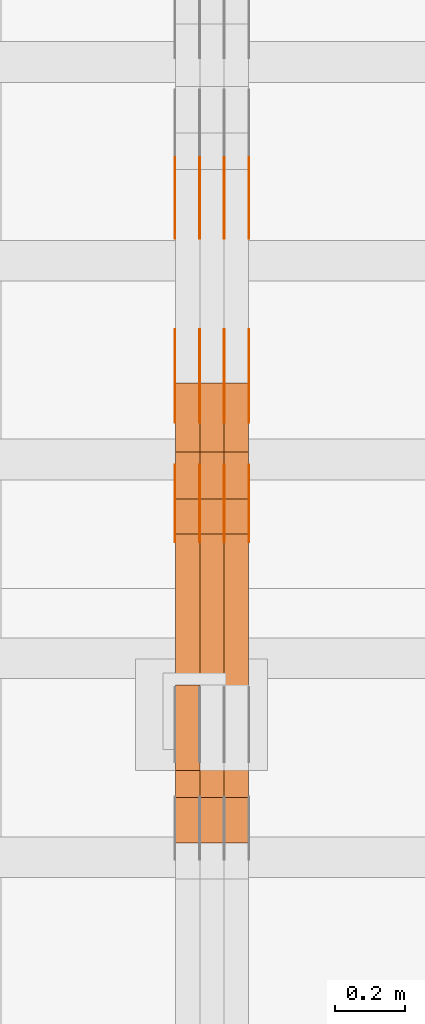
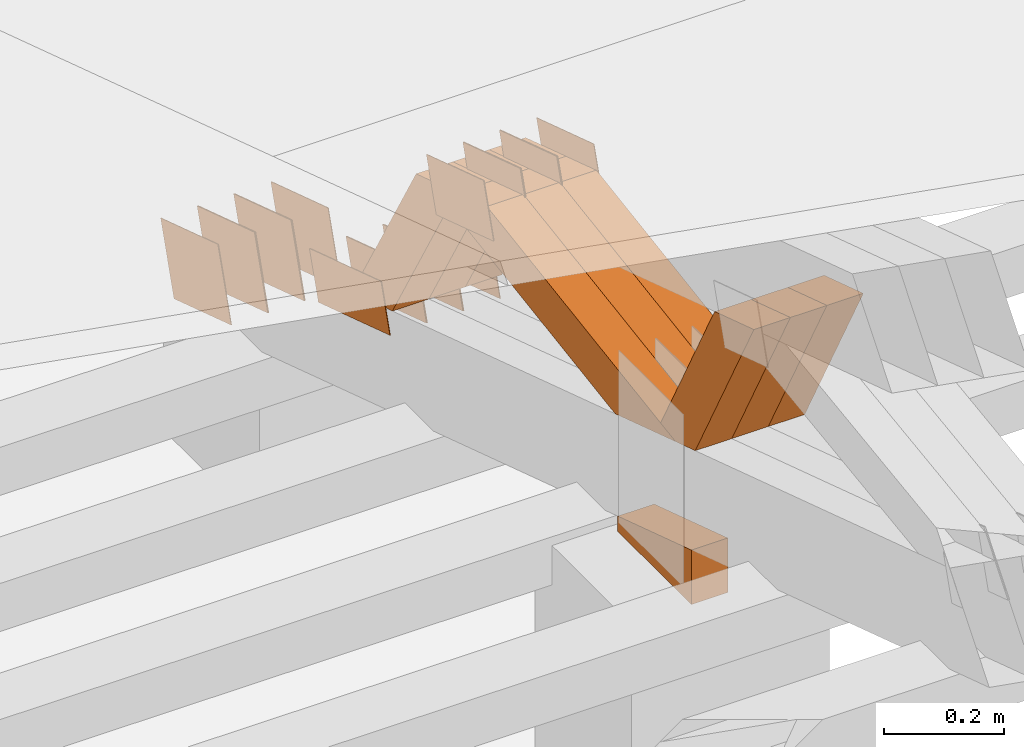
# One storey, part 304 of 385: 28 proxies.
"""IFC2X3 building model written with IfcOpenShell, lengths in millimetres."""

from ifc_helpers import new_model, entity, si_unit, converted_unit, derived_unit, direction, frame, origin, place, context, subcontext, project, spatial, polyline, outline, extrude, source, transform, mapped, material, type_object, type_shapes, element, save


model = new_model("IFC2X3")

# Units and contexts
model_context = context("Model", 3, precision=0.01, world=origin(), true_north=direction((6.12303176911189e-17, 1.0)))
body_context = subcontext(model_context, "Body", "Model", "MODEL_VIEW")
ifc_project = project(units=[si_unit("LENGTHUNIT", "METRE", prefix="MILLI"), si_unit("AREAUNIT", "SQUARE_METRE"), si_unit("VOLUMEUNIT", "CUBIC_METRE"), converted_unit("PLANEANGLEUNIT", "DEGREE", entity("IfcRatioMeasure", 0.0174532925199433), si_unit("PLANEANGLEUNIT", "RADIAN"), dimensions=[0, 0, 0, 0, 0, 0, 0]), si_unit("MASSUNIT", "GRAM", prefix="KILO"), derived_unit("MASSDENSITYUNIT", [(si_unit("MASSUNIT", "GRAM", prefix="KILO"), 1), (si_unit("LENGTHUNIT", "METRE"), -3)]), si_unit("TIMEUNIT", "SECOND"), si_unit("FREQUENCYUNIT", "HERTZ"), si_unit("THERMODYNAMICTEMPERATUREUNIT", "DEGREE_CELSIUS"), derived_unit("THERMALTRANSMITTANCEUNIT", [(si_unit("MASSUNIT", "GRAM", prefix="KILO"), 1), (si_unit("THERMODYNAMICTEMPERATUREUNIT", "KELVIN"), -1), (si_unit("TIMEUNIT", "SECOND"), -3)]), derived_unit("VOLUMETRICFLOWRATEUNIT", [(si_unit("LENGTHUNIT", "METRE"), 3), (si_unit("TIMEUNIT", "SECOND"), -1)]), si_unit("ELECTRICCURRENTUNIT", "AMPERE"), si_unit("ELECTRICVOLTAGEUNIT", "VOLT"), si_unit("POWERUNIT", "WATT"), si_unit("FORCEUNIT", "NEWTON", prefix="KILO"), si_unit("ILLUMINANCEUNIT", "LUX"), si_unit("LUMINOUSFLUXUNIT", "LUMEN"), si_unit("LUMINOUSINTENSITYUNIT", "CANDELA"), derived_unit("USERDEFINED", [(si_unit("MASSUNIT", "GRAM", prefix="KILO"), -1), (si_unit("LENGTHUNIT", "METRE"), -2), (si_unit("TIMEUNIT", "SECOND"), 3), (si_unit("LUMINOUSFLUXUNIT", "LUMEN"), 1)]), derived_unit("LINEARVELOCITYUNIT", [(si_unit("LENGTHUNIT", "METRE"), 1), (si_unit("TIMEUNIT", "SECOND"), -1)]), si_unit("PRESSUREUNIT", "PASCAL"), derived_unit("USERDEFINED", [(si_unit("LENGTHUNIT", "METRE"), -2), (si_unit("MASSUNIT", "GRAM", prefix="KILO"), 1), (si_unit("TIMEUNIT", "SECOND"), -2)])], contexts=[model_context])

# Site, building, storey
site_placement = place(None, origin())
site = spatial("IfcSite", under=ifc_project, at=site_placement, CompositionType="ELEMENT")
building_placement = place(site_placement, origin())
building = spatial("IfcBuilding", under=site, at=building_placement, CompositionType="ELEMENT")
storey_placement = place(building_placement, origin())
storey = spatial("IfcBuildingStorey", under=building, at=storey_placement, Name="Default", CompositionType="ELEMENT", Elevation=0.0)

# Proxies
ifc_material_1 = material(Name="IfcSurfaceStyle #549014")
building_element_proxy_type_1 = type_object("IfcBuildingElementProxyType", PredefinedType="NOTDEFINED", material=ifc_material_1)
shared_shape_1 = source(origin(), body_context, "Body", "SweptSolid", [
    extrude(outline(polyline([(-125.00031378339, -47.9999612158856), (125.000225258022, -47.9999612158856), (124.999811678525, 47.9999612158856), (-124.999723153156, 47.9999612158856), (-125.00031378339, -47.9999612158856)])), frame((125.000225258022, 48.0000091013474, 0.0), z_axis=(0.0, 0.0, 1.0), x_axis=(-1.0, 0.0, 0.0)), (0.0, 0.0, 1.0), 1.3),
])
type_shapes(building_element_proxy_type_1, [shared_shape_1])
proxy_1_placement = place(building_placement, frame((45386.3, 18456.8597683375, 2657.46691321253), z_axis=(-1.0, 0.0, 0.0), x_axis=(0.0, -0.951056516295124, 0.309016994375039)))
element("IfcBuildingElementProxy", 1, at=proxy_1_placement, inside=storey, type_object=building_element_proxy_type_1, material=ifc_material_1, context=body_context, shape_type="MappedRepresentation", body=[
    mapped(shared_shape_1, transform((0.0, 0.0, 0.0), scale=1.0)),
])
ifc_material_2 = material(Name="IfcSurfaceStyle #548957")
building_element_proxy_type_2 = type_object("IfcBuildingElementProxyType", PredefinedType="NOTDEFINED", material=ifc_material_2)
shared_shape_2 = source(origin(), body_context, "Body", "SweptSolid", [
    extrude(outline(polyline([(-125.00031378339, -47.9999612158856), (125.000225258022, -47.9999612158856), (124.999811678525, 47.9999612158856), (-124.999723153156, 47.9999612158856), (-125.00031378339, -47.9999612158856)])), frame((125.000225258022, 48.0000091013474, 0.0), z_axis=(0.0, 0.0, 1.0), x_axis=(-1.0, 0.0, 0.0)), (0.0, 0.0, 1.0), 1.3),
])
type_shapes(building_element_proxy_type_2, [shared_shape_2])
proxy_2_placement = place(building_placement, frame((45315.0, 18456.8597683375, 2657.46691321253), z_axis=(-1.0, 0.0, 0.0), x_axis=(0.0, -0.951056516295124, 0.309016994375039)))
element("IfcBuildingElementProxy", 2, at=proxy_2_placement, inside=storey, type_object=building_element_proxy_type_2, material=ifc_material_2, context=body_context, shape_type="MappedRepresentation", body=[
    mapped(shared_shape_2, transform((0.0, 0.0, 0.0), scale=1.0)),
])
ifc_material_3 = material(Name="IfcSurfaceStyle #548900")
building_element_proxy_type_3 = type_object("IfcBuildingElementProxyType", PredefinedType="NOTDEFINED", material=ifc_material_3)
shared_shape_3 = source(origin(), body_context, "Body", "SweptSolid", [
    extrude(outline(polyline([(-125.00031378339, -47.9999612158856), (125.000225258022, -47.9999612158856), (124.999811678525, 47.9999612158856), (-124.999723153156, 47.9999612158856), (-125.00031378339, -47.9999612158856)])), frame((125.000225258022, 48.0000091013474, 0.0), z_axis=(0.0, 0.0, 1.0), x_axis=(-1.0, 0.0, 0.0)), (0.0, 0.0, 1.0), 1.3),
])
type_shapes(building_element_proxy_type_3, [shared_shape_3])
proxy_3_placement = place(building_placement, frame((45316.3, 18456.8597683375, 2657.46691321253), z_axis=(-1.0, 0.0, 0.0), x_axis=(0.0, -0.951056516295124, 0.309016994375039)))
element("IfcBuildingElementProxy", 3, at=proxy_3_placement, inside=storey, type_object=building_element_proxy_type_3, material=ifc_material_3, context=body_context, shape_type="MappedRepresentation", body=[
    mapped(shared_shape_3, transform((0.0, 0.0, 0.0), scale=1.0)),
])
ifc_material_4 = material(Name="IfcSurfaceStyle #548843")
building_element_proxy_type_4 = type_object("IfcBuildingElementProxyType", PredefinedType="NOTDEFINED", material=ifc_material_4)
shared_shape_4 = source(origin(), body_context, "Body", "SweptSolid", [
    extrude(outline(polyline([(-125.00031378339, -47.9999612158856), (125.000225258022, -47.9999612158856), (124.999811678525, 47.9999612158856), (-124.999723153156, 47.9999612158856), (-125.00031378339, -47.9999612158856)])), frame((125.000225258022, 48.0000091013474, 0.0), z_axis=(0.0, 0.0, 1.0), x_axis=(-1.0, 0.0, 0.0)), (0.0, 0.0, 1.0), 1.29999999999998),
])
type_shapes(building_element_proxy_type_4, [shared_shape_4])
proxy_4_placement = place(building_placement, frame((45245.0, 18456.8597683375, 2657.46691321253), z_axis=(-1.0, 0.0, 0.0), x_axis=(0.0, -0.951056516295124, 0.309016994375039)))
element("IfcBuildingElementProxy", 4, at=proxy_4_placement, inside=storey, type_object=building_element_proxy_type_4, material=ifc_material_4, context=body_context, shape_type="MappedRepresentation", body=[
    mapped(shared_shape_4, transform((0.0, 0.0, 0.0), scale=1.0)),
])
ifc_material_5 = material(Name="IfcSurfaceStyle #548786")
building_element_proxy_type_5 = type_object("IfcBuildingElementProxyType", PredefinedType="NOTDEFINED", material=ifc_material_5)
shared_shape_5 = source(origin(), body_context, "Body", "SweptSolid", [
    extrude(outline(polyline([(-125.00031378339, -47.9999612158856), (125.000225258022, -47.9999612158856), (124.999811678525, 47.9999612158856), (-124.999723153156, 47.9999612158856), (-125.00031378339, -47.9999612158856)])), frame((125.000225258022, 48.0000091013474, 0.0), z_axis=(0.0, 0.0, 1.0), x_axis=(-1.0, 0.0, 0.0)), (0.0, 0.0, 1.0), 1.29999999999998),
])
type_shapes(building_element_proxy_type_5, [shared_shape_5])
proxy_5_placement = place(building_placement, frame((45246.3, 18456.8597683375, 2657.46691321253), z_axis=(-1.0, 0.0, 0.0), x_axis=(0.0, -0.951056516295124, 0.309016994375039)))
element("IfcBuildingElementProxy", 5, at=proxy_5_placement, inside=storey, type_object=building_element_proxy_type_5, material=ifc_material_5, context=body_context, shape_type="MappedRepresentation", body=[
    mapped(shared_shape_5, transform((0.0, 0.0, 0.0), scale=1.0)),
])
ifc_material_6 = material(Name="IfcSurfaceStyle #548729")
building_element_proxy_type_6 = type_object("IfcBuildingElementProxyType", PredefinedType="NOTDEFINED", material=ifc_material_6)
shared_shape_6 = source(origin(), body_context, "Body", "SweptSolid", [
    extrude(outline(polyline([(-125.00031378339, -47.9999612158856), (125.000225258022, -47.9999612158856), (124.999811678525, 47.9999612158856), (-124.999723153156, 47.9999612158856), (-125.00031378339, -47.9999612158856)])), frame((125.000225258022, 48.0000091013474, 0.0), z_axis=(0.0, 0.0, 1.0), x_axis=(-1.0, 0.0, 0.0)), (0.0, 0.0, 1.0), 1.29999999999998),
])
type_shapes(building_element_proxy_type_6, [shared_shape_6])
proxy_6_placement = place(building_placement, frame((45175.0, 18456.8597683375, 2657.46691321253), z_axis=(-1.0, 0.0, 0.0), x_axis=(0.0, -0.951056516295124, 0.309016994375039)))
element("IfcBuildingElementProxy", 6, at=proxy_6_placement, inside=storey, type_object=building_element_proxy_type_6, material=ifc_material_6, context=body_context, shape_type="MappedRepresentation", body=[
    mapped(shared_shape_6, transform((0.0, 0.0, 0.0), scale=1.0)),
])
ifc_material_7 = material(Name="IfcSurfaceStyle #547304")
building_element_proxy_type_7 = type_object("IfcBuildingElementProxyType", PredefinedType="NOTDEFINED", material=ifc_material_7)
shared_shape_7 = source(origin(), body_context, "Body", "SweptSolid", [
    extrude(outline(polyline([(-99.999796294464, -72.0000050220467), (99.9998768370438, -72.0000050220467), (100.000260677528, 72.0000050220467), (-100.000341220108, 72.0000050220467), (-99.999796294464, -72.0000050220467)])), frame((100.000260677528, 72.0000050220467, 0.0), z_axis=(0.0, 0.0, 1.0), x_axis=(-1.0, 0.0, 0.0)), (0.0, 0.0, 1.0), 1.3),
])
type_shapes(building_element_proxy_type_7, [shared_shape_7])
proxy_7_placement = place(building_placement, frame((45386.3, 18936.3876569477, 2373.90613192527), z_axis=(-1.0, 0.0, 0.0), x_axis=(0.0, -0.951056516295124, 0.309016994375039)))
element("IfcBuildingElementProxy", 7, at=proxy_7_placement, inside=storey, type_object=building_element_proxy_type_7, material=ifc_material_7, context=body_context, shape_type="MappedRepresentation", body=[
    mapped(shared_shape_7, transform((0.0, 0.0, 0.0), scale=1.0)),
])
ifc_material_8 = material(Name="IfcSurfaceStyle #547247")
building_element_proxy_type_8 = type_object("IfcBuildingElementProxyType", PredefinedType="NOTDEFINED", material=ifc_material_8)
shared_shape_8 = source(origin(), body_context, "Body", "SweptSolid", [
    extrude(outline(polyline([(-99.999796294464, -72.0000050220467), (99.9998768370438, -72.0000050220467), (100.000260677528, 72.0000050220467), (-100.000341220108, 72.0000050220467), (-99.999796294464, -72.0000050220467)])), frame((100.000260677528, 72.0000050220467, 0.0), z_axis=(0.0, 0.0, 1.0), x_axis=(-1.0, 0.0, 0.0)), (0.0, 0.0, 1.0), 1.3),
])
type_shapes(building_element_proxy_type_8, [shared_shape_8])
proxy_8_placement = place(building_placement, frame((45315.0, 18936.3876569477, 2373.90613192527), z_axis=(-1.0, 0.0, 0.0), x_axis=(0.0, -0.951056516295124, 0.309016994375039)))
element("IfcBuildingElementProxy", 8, at=proxy_8_placement, inside=storey, type_object=building_element_proxy_type_8, material=ifc_material_8, context=body_context, shape_type="MappedRepresentation", body=[
    mapped(shared_shape_8, transform((0.0, 0.0, 0.0), scale=1.0)),
])
ifc_material_9 = material(Name="IfcSurfaceStyle #547190")
building_element_proxy_type_9 = type_object("IfcBuildingElementProxyType", PredefinedType="NOTDEFINED", material=ifc_material_9)
shared_shape_9 = source(origin(), body_context, "Body", "SweptSolid", [
    extrude(outline(polyline([(-99.999796294464, -72.0000050220467), (99.9998768370438, -72.0000050220467), (100.000260677528, 72.0000050220467), (-100.000341220108, 72.0000050220467), (-99.999796294464, -72.0000050220467)])), frame((100.000260677528, 72.0000050220467, 0.0), z_axis=(0.0, 0.0, 1.0), x_axis=(-1.0, 0.0, 0.0)), (0.0, 0.0, 1.0), 1.3),
])
type_shapes(building_element_proxy_type_9, [shared_shape_9])
proxy_9_placement = place(building_placement, frame((45316.3, 18936.3876569477, 2373.90613192527), z_axis=(-1.0, 0.0, 0.0), x_axis=(0.0, -0.951056516295124, 0.309016994375039)))
element("IfcBuildingElementProxy", 9, at=proxy_9_placement, inside=storey, type_object=building_element_proxy_type_9, material=ifc_material_9, context=body_context, shape_type="MappedRepresentation", body=[
    mapped(shared_shape_9, transform((0.0, 0.0, 0.0), scale=1.0)),
])
ifc_material_10 = material(Name="IfcSurfaceStyle #547133")
building_element_proxy_type_10 = type_object("IfcBuildingElementProxyType", PredefinedType="NOTDEFINED", material=ifc_material_10)
shared_shape_10 = source(origin(), body_context, "Body", "SweptSolid", [
    extrude(outline(polyline([(-99.999796294464, -72.0000050220467), (99.9998768370438, -72.0000050220467), (100.000260677528, 72.0000050220467), (-100.000341220108, 72.0000050220467), (-99.999796294464, -72.0000050220467)])), frame((100.000260677528, 72.0000050220467, 0.0), z_axis=(0.0, 0.0, 1.0), x_axis=(-1.0, 0.0, 0.0)), (0.0, 0.0, 1.0), 1.29999999999998),
])
type_shapes(building_element_proxy_type_10, [shared_shape_10])
proxy_10_placement = place(building_placement, frame((45245.0, 18936.3876569477, 2373.90613192527), z_axis=(-1.0, 0.0, 0.0), x_axis=(0.0, -0.951056516295124, 0.309016994375039)))
element("IfcBuildingElementProxy", 10, at=proxy_10_placement, inside=storey, type_object=building_element_proxy_type_10, material=ifc_material_10, context=body_context, shape_type="MappedRepresentation", body=[
    mapped(shared_shape_10, transform((0.0, 0.0, 0.0), scale=1.0)),
])
ifc_material_11 = material(Name="IfcSurfaceStyle #547076")
building_element_proxy_type_11 = type_object("IfcBuildingElementProxyType", PredefinedType="NOTDEFINED", material=ifc_material_11)
shared_shape_11 = source(origin(), body_context, "Body", "SweptSolid", [
    extrude(outline(polyline([(-99.999796294464, -72.0000050220467), (99.9998768370438, -72.0000050220467), (100.000260677528, 72.0000050220467), (-100.000341220108, 72.0000050220467), (-99.999796294464, -72.0000050220467)])), frame((100.000260677528, 72.0000050220467, 0.0), z_axis=(0.0, 0.0, 1.0), x_axis=(-1.0, 0.0, 0.0)), (0.0, 0.0, 1.0), 1.29999999999998),
])
type_shapes(building_element_proxy_type_11, [shared_shape_11])
proxy_11_placement = place(building_placement, frame((45246.3, 18936.3876569477, 2373.90613192527), z_axis=(-1.0, 0.0, 0.0), x_axis=(0.0, -0.951056516295124, 0.309016994375039)))
element("IfcBuildingElementProxy", 11, at=proxy_11_placement, inside=storey, type_object=building_element_proxy_type_11, material=ifc_material_11, context=body_context, shape_type="MappedRepresentation", body=[
    mapped(shared_shape_11, transform((0.0, 0.0, 0.0), scale=1.0)),
])
ifc_material_12 = material(Name="IfcSurfaceStyle #547019")
building_element_proxy_type_12 = type_object("IfcBuildingElementProxyType", PredefinedType="NOTDEFINED", material=ifc_material_12)
shared_shape_12 = source(origin(), body_context, "Body", "SweptSolid", [
    extrude(outline(polyline([(-99.999796294464, -72.0000050220467), (99.9998768370438, -72.0000050220467), (100.000260677528, 72.0000050220467), (-100.000341220108, 72.0000050220467), (-99.999796294464, -72.0000050220467)])), frame((100.000260677528, 72.0000050220467, 0.0), z_axis=(0.0, 0.0, 1.0), x_axis=(-1.0, 0.0, 0.0)), (0.0, 0.0, 1.0), 1.29999999999999),
])
type_shapes(building_element_proxy_type_12, [shared_shape_12])
proxy_12_placement = place(building_placement, frame((45175.0, 18936.3876569477, 2373.90613192527), z_axis=(-1.0, 0.0, 0.0), x_axis=(0.0, -0.951056516295124, 0.309016994375039)))
element("IfcBuildingElementProxy", 12, at=proxy_12_placement, inside=storey, type_object=building_element_proxy_type_12, material=ifc_material_12, context=body_context, shape_type="MappedRepresentation", body=[
    mapped(shared_shape_12, transform((0.0, 0.0, 0.0), scale=1.0)),
])
ifc_material_13 = material(Name="IfcSurfaceStyle #542858")
building_element_proxy_type_13 = type_object("IfcBuildingElementProxyType", PredefinedType="NOTDEFINED", material=ifc_material_13)
shared_shape_13 = source(origin(), body_context, "Body", "SweptSolid", [
    extrude(outline(polyline([(-99.9999427841299, -54.0000599375792), (99.9996549037756, -54.0000599375792), (100.000407167194, 54.0000599375792), (-100.00011928684, 54.0000599375792), (-99.9999427841299, -54.0000599375792)])), frame((100.000407167194, 54.0000599375792, 0.0), z_axis=(0.0, 0.0, 1.0), x_axis=(-1.0, 0.0, 0.0)), (0.0, 0.0, 1.0), 1.3),
])
type_shapes(building_element_proxy_type_13, [shared_shape_13])
proxy_13_placement = place(building_placement, frame((45386.3, 18065.0682492591, 3072.55239547302), z_axis=(-1.0, 0.0, 0.0), x_axis=(0.0, -0.951056516295154, 0.309016994374948)))
element("IfcBuildingElementProxy", 13, at=proxy_13_placement, inside=storey, type_object=building_element_proxy_type_13, material=ifc_material_13, context=body_context, shape_type="MappedRepresentation", body=[
    mapped(shared_shape_13, transform((0.0, 0.0, 0.0), scale=1.0)),
])
ifc_material_14 = material(Name="IfcSurfaceStyle #542801")
building_element_proxy_type_14 = type_object("IfcBuildingElementProxyType", PredefinedType="NOTDEFINED", material=ifc_material_14)
shared_shape_14 = source(origin(), body_context, "Body", "SweptSolid", [
    extrude(outline(polyline([(-99.9999427841299, -54.0000599375792), (99.9996549037756, -54.0000599375792), (100.000407167194, 54.0000599375792), (-100.00011928684, 54.0000599375792), (-99.9999427841299, -54.0000599375792)])), frame((100.000407167194, 54.0000599375792, 0.0), z_axis=(0.0, 0.0, 1.0), x_axis=(-1.0, 0.0, 0.0)), (0.0, 0.0, 1.0), 1.3),
])
type_shapes(building_element_proxy_type_14, [shared_shape_14])
proxy_14_placement = place(building_placement, frame((45315.0, 18065.0682492591, 3072.55239547302), z_axis=(-1.0, 0.0, 0.0), x_axis=(0.0, -0.951056516295154, 0.309016994374948)))
element("IfcBuildingElementProxy", 14, at=proxy_14_placement, inside=storey, type_object=building_element_proxy_type_14, material=ifc_material_14, context=body_context, shape_type="MappedRepresentation", body=[
    mapped(shared_shape_14, transform((0.0, 0.0, 0.0), scale=1.0)),
])
ifc_material_15 = material(Name="IfcSurfaceStyle #542744")
building_element_proxy_type_15 = type_object("IfcBuildingElementProxyType", PredefinedType="NOTDEFINED", material=ifc_material_15)
shared_shape_15 = source(origin(), body_context, "Body", "SweptSolid", [
    extrude(outline(polyline([(-99.9999427841299, -54.0000599375792), (99.9996549037756, -54.0000599375792), (100.000407167194, 54.0000599375792), (-100.00011928684, 54.0000599375792), (-99.9999427841299, -54.0000599375792)])), frame((100.000407167194, 54.0000599375792, 0.0), z_axis=(0.0, 0.0, 1.0), x_axis=(-1.0, 0.0, 0.0)), (0.0, 0.0, 1.0), 1.3),
])
type_shapes(building_element_proxy_type_15, [shared_shape_15])
proxy_15_placement = place(building_placement, frame((45316.3, 18065.0682492591, 3072.55239547302), z_axis=(-1.0, 0.0, 0.0), x_axis=(0.0, -0.951056516295154, 0.309016994374948)))
element("IfcBuildingElementProxy", 15, at=proxy_15_placement, inside=storey, type_object=building_element_proxy_type_15, material=ifc_material_15, context=body_context, shape_type="MappedRepresentation", body=[
    mapped(shared_shape_15, transform((0.0, 0.0, 0.0), scale=1.0)),
])
ifc_material_16 = material(Name="IfcSurfaceStyle #542687")
building_element_proxy_type_16 = type_object("IfcBuildingElementProxyType", PredefinedType="NOTDEFINED", material=ifc_material_16)
shared_shape_16 = source(origin(), body_context, "Body", "SweptSolid", [
    extrude(outline(polyline([(-99.9999427841299, -54.0000599375792), (99.9996549037756, -54.0000599375792), (100.000407167194, 54.0000599375792), (-100.00011928684, 54.0000599375792), (-99.9999427841299, -54.0000599375792)])), frame((100.000407167194, 54.0000599375792, 0.0), z_axis=(0.0, 0.0, 1.0), x_axis=(-1.0, 0.0, 0.0)), (0.0, 0.0, 1.0), 1.29999999999998),
])
type_shapes(building_element_proxy_type_16, [shared_shape_16])
proxy_16_placement = place(building_placement, frame((45245.0, 18065.0682492591, 3072.55239547302), z_axis=(-1.0, 0.0, 0.0), x_axis=(0.0, -0.951056516295154, 0.309016994374948)))
element("IfcBuildingElementProxy", 16, at=proxy_16_placement, inside=storey, type_object=building_element_proxy_type_16, material=ifc_material_16, context=body_context, shape_type="MappedRepresentation", body=[
    mapped(shared_shape_16, transform((0.0, 0.0, 0.0), scale=1.0)),
])
ifc_material_17 = material(Name="IfcSurfaceStyle #542630")
building_element_proxy_type_17 = type_object("IfcBuildingElementProxyType", PredefinedType="NOTDEFINED", material=ifc_material_17)
shared_shape_17 = source(origin(), body_context, "Body", "SweptSolid", [
    extrude(outline(polyline([(-99.9999427841299, -54.0000599375792), (99.9996549037756, -54.0000599375792), (100.000407167194, 54.0000599375792), (-100.00011928684, 54.0000599375792), (-99.9999427841299, -54.0000599375792)])), frame((100.000407167194, 54.0000599375792, 0.0), z_axis=(0.0, 0.0, 1.0), x_axis=(-1.0, 0.0, 0.0)), (0.0, 0.0, 1.0), 1.29999999999998),
])
type_shapes(building_element_proxy_type_17, [shared_shape_17])
proxy_17_placement = place(building_placement, frame((45246.3, 18065.0682492591, 3072.55239547302), z_axis=(-1.0, 0.0, 0.0), x_axis=(0.0, -0.951056516295154, 0.309016994374948)))
element("IfcBuildingElementProxy", 17, at=proxy_17_placement, inside=storey, type_object=building_element_proxy_type_17, material=ifc_material_17, context=body_context, shape_type="MappedRepresentation", body=[
    mapped(shared_shape_17, transform((0.0, 0.0, 0.0), scale=1.0)),
])
ifc_material_18 = material(Name="IfcSurfaceStyle #542573")
building_element_proxy_type_18 = type_object("IfcBuildingElementProxyType", PredefinedType="NOTDEFINED", material=ifc_material_18)
shared_shape_18 = source(origin(), body_context, "Body", "SweptSolid", [
    extrude(outline(polyline([(-99.9999427841299, -54.0000599375792), (99.9996549037756, -54.0000599375792), (100.000407167194, 54.0000599375792), (-100.00011928684, 54.0000599375792), (-99.9999427841299, -54.0000599375792)])), frame((100.000407167194, 54.0000599375792, 0.0), z_axis=(0.0, 0.0, 1.0), x_axis=(-1.0, 0.0, 0.0)), (0.0, 0.0, 1.0), 1.29999999999999),
])
type_shapes(building_element_proxy_type_18, [shared_shape_18])
proxy_18_placement = place(building_placement, frame((45175.0, 18065.0682492591, 3072.55239547302), z_axis=(-1.0, 0.0, 0.0), x_axis=(0.0, -0.951056516295154, 0.309016994374948)))
element("IfcBuildingElementProxy", 18, at=proxy_18_placement, inside=storey, type_object=building_element_proxy_type_18, material=ifc_material_18, context=body_context, shape_type="MappedRepresentation", body=[
    mapped(shared_shape_18, transform((0.0, 0.0, 0.0), scale=1.0)),
])
ifc_material_19 = material(Name="IfcSurfaceStyle #535139")
building_element_proxy_type_19 = type_object("IfcBuildingElementProxyType", Name="T1-E1 535137", PredefinedType="NOTDEFINED", material=ifc_material_19)
shared_shape_19 = source(origin(), body_context, "Body", "SweptSolid", [
    extrude(outline(polyline([(4.4675903320374, -122.500000000001), (35.3350219726624, -122.500000000001), (35.3350219726501, 122.500000000001), (-75.1376342773499, 122.500000000001), (4.4675903320374, -122.500000000001)])), frame((35.3350219726624, 122.50000005215, 0.0), z_axis=(0.0, 0.0, 1.0), x_axis=(-1.0, 0.0, 0.0)), (0.0, 0.0, 1.0), 70.0),
])
type_shapes(building_element_proxy_type_19, [shared_shape_19])
proxy_19_placement = place(building_placement, frame((45245.0, 17220.0, 2794.30932617186), z_axis=(-1.0, 0.0, 0.0), x_axis=(0.0, 0.0, 1.0)))
element("IfcBuildingElementProxy", 19, at=proxy_19_placement, inside=storey, type_object=building_element_proxy_type_19, material=ifc_material_19, Name="T1-E1", context=body_context, shape_type="MappedRepresentation", body=[
    mapped(shared_shape_19, transform((0.0, 0.0, 0.0), scale=1.0)),
])
ifc_material_20 = material(Name="IfcSurfaceStyle #533498")
building_element_proxy_type_20 = type_object("IfcBuildingElementProxyType", Name="T1-W39 533496", PredefinedType="NOTDEFINED", material=ifc_material_20)
shared_shape_20 = source(origin(), body_context, "Body", "SweptSolid", [
    extrude(outline(polyline([(-191.519946663886, -47.499928106579), (188.32936223763, -47.499928106579), (171.597440144109, 0.000249483340993841), (122.102882529753, 47.4998033649085), (-290.509738247605, 47.4998033649085), (-191.519946663886, -47.499928106579)])), frame((188.329593252001, 47.499957247623, 0.0), z_axis=(0.0, 0.0, 1.0), x_axis=(-1.0, 0.0, 0.0)), (0.0, 0.0, 1.0), 70.0),
])
type_shapes(building_element_proxy_type_20, [shared_shape_20])
proxy_20_placement = place(building_placement, frame((45385.0, 17238.5876916597, 3055.56121424762), z_axis=(-1.0, 0.0, 0.0), x_axis=(0.0, -0.472216932390777, 0.881482370080902)))
element("IfcBuildingElementProxy", 20, at=proxy_20_placement, inside=storey, type_object=building_element_proxy_type_20, material=ifc_material_20, Name="T1-W39", context=body_context, shape_type="MappedRepresentation", body=[
    mapped(shared_shape_20, transform((0.0, 0.0, 0.0), scale=1.0)),
])
ifc_material_21 = material(Name="IfcSurfaceStyle #533432")
building_element_proxy_type_21 = type_object("IfcBuildingElementProxyType", Name="T1-W39 533430", PredefinedType="NOTDEFINED", material=ifc_material_21)
shared_shape_21 = source(origin(), body_context, "Body", "SweptSolid", [
    extrude(outline(polyline([(-191.519946663886, -47.499928106579), (188.32936223763, -47.499928106579), (171.597440144109, 0.000249483340993841), (122.102882529753, 47.4998033649085), (-290.509738247605, 47.4998033649085), (-191.519946663886, -47.499928106579)])), frame((188.329593252001, 47.499957247623, 0.0), z_axis=(0.0, 0.0, 1.0), x_axis=(-1.0, 0.0, 0.0)), (0.0, 0.0, 1.0), 70.0),
])
type_shapes(building_element_proxy_type_21, [shared_shape_21])
proxy_21_placement = place(building_placement, frame((45315.0, 17238.5876916597, 3055.56121424762), z_axis=(-1.0, 0.0, 0.0), x_axis=(0.0, -0.472216932390777, 0.881482370080902)))
element("IfcBuildingElementProxy", 21, at=proxy_21_placement, inside=storey, type_object=building_element_proxy_type_21, material=ifc_material_21, Name="T1-W39", context=body_context, shape_type="MappedRepresentation", body=[
    mapped(shared_shape_21, transform((0.0, 0.0, 0.0), scale=1.0)),
])
ifc_material_22 = material(Name="IfcSurfaceStyle #533366")
building_element_proxy_type_22 = type_object("IfcBuildingElementProxyType", Name="T1-W39 533364", PredefinedType="NOTDEFINED", material=ifc_material_22)
shared_shape_22 = source(origin(), body_context, "Body", "SweptSolid", [
    extrude(outline(polyline([(-191.519946663886, -47.499928106579), (188.32936223763, -47.499928106579), (171.597440144109, 0.000249483340993841), (122.102882529753, 47.4998033649085), (-290.509738247605, 47.4998033649085), (-191.519946663886, -47.499928106579)])), frame((188.329593252001, 47.499957247623, 0.0), z_axis=(0.0, 0.0, 1.0), x_axis=(-1.0, 0.0, 0.0)), (0.0, 0.0, 1.0), 70.0),
])
type_shapes(building_element_proxy_type_22, [shared_shape_22])
proxy_22_placement = place(building_placement, frame((45245.0, 17238.5876916597, 3055.56121424762), z_axis=(-1.0, 0.0, 0.0), x_axis=(0.0, -0.472216932390777, 0.881482370080902)))
element("IfcBuildingElementProxy", 22, at=proxy_22_placement, inside=storey, type_object=building_element_proxy_type_22, material=ifc_material_22, Name="T1-W39", context=body_context, shape_type="MappedRepresentation", body=[
    mapped(shared_shape_22, transform((0.0, 0.0, 0.0), scale=1.0)),
])
ifc_material_23 = material(Name="IfcSurfaceStyle #533102")
building_element_proxy_type_23 = type_object("IfcBuildingElementProxyType", Name="T1-W10 533100", PredefinedType="NOTDEFINED", material=ifc_material_23)
shared_shape_23 = source(origin(), body_context, "Body", "SweptSolid", [
    extrude(outline(polyline([(-459.546036710757, -47.5000436364511), (174.689450869018, -47.5000436364511), (268.831081103959, 0.00011114562912502), (287.286350706789, 47.4999880636365), (-271.260845969009, 47.4999880636366), (-459.546036710757, -47.5000436364511)])), frame((287.286768781132, 47.5001637448091, 0.0), z_axis=(0.0, 0.0, 1.0), x_axis=(-1.0, 0.0, 0.0)), (0.0, 0.0, 1.0), 70.0),
])
type_shapes(building_element_proxy_type_23, [shared_shape_23])
proxy_23_placement = place(building_placement, frame((45385.0, 18025.1410649788, 3112.76453857986), z_axis=(-1.0, 0.0, 0.0), x_axis=(0.0, -0.988299196256916, -0.152527698068035)))
element("IfcBuildingElementProxy", 23, at=proxy_23_placement, inside=storey, type_object=building_element_proxy_type_23, material=ifc_material_23, Name="T1-W10", context=body_context, shape_type="MappedRepresentation", body=[
    mapped(shared_shape_23, transform((0.0, 0.0, 0.0), scale=1.0)),
])
ifc_material_24 = material(Name="IfcSurfaceStyle #533036")
building_element_proxy_type_24 = type_object("IfcBuildingElementProxyType", Name="T1-W10 533034", PredefinedType="NOTDEFINED", material=ifc_material_24)
shared_shape_24 = source(origin(), body_context, "Body", "SweptSolid", [
    extrude(outline(polyline([(-459.546036710757, -47.5000436364511), (174.689450869018, -47.5000436364511), (268.831081103959, 0.00011114562912502), (287.286350706789, 47.4999880636365), (-271.260845969009, 47.4999880636366), (-459.546036710757, -47.5000436364511)])), frame((287.286768781132, 47.5001637448091, 0.0), z_axis=(0.0, 0.0, 1.0), x_axis=(-1.0, 0.0, 0.0)), (0.0, 0.0, 1.0), 70.0),
])
type_shapes(building_element_proxy_type_24, [shared_shape_24])
proxy_24_placement = place(building_placement, frame((45315.0, 18025.1410649788, 3112.76453857986), z_axis=(-1.0, 0.0, 0.0), x_axis=(0.0, -0.988299196256916, -0.152527698068035)))
element("IfcBuildingElementProxy", 24, at=proxy_24_placement, inside=storey, type_object=building_element_proxy_type_24, material=ifc_material_24, Name="T1-W10", context=body_context, shape_type="MappedRepresentation", body=[
    mapped(shared_shape_24, transform((0.0, 0.0, 0.0), scale=1.0)),
])
ifc_material_25 = material(Name="IfcSurfaceStyle #532970")
building_element_proxy_type_25 = type_object("IfcBuildingElementProxyType", Name="T1-W10 532968", PredefinedType="NOTDEFINED", material=ifc_material_25)
shared_shape_25 = source(origin(), body_context, "Body", "SweptSolid", [
    extrude(outline(polyline([(-459.546036710757, -47.5000436364511), (174.689450869018, -47.5000436364511), (268.831081103959, 0.00011114562912502), (287.286350706789, 47.4999880636365), (-271.260845969009, 47.4999880636366), (-459.546036710757, -47.5000436364511)])), frame((287.286768781132, 47.5001637448091, 0.0), z_axis=(0.0, 0.0, 1.0), x_axis=(-1.0, 0.0, 0.0)), (0.0, 0.0, 1.0), 70.0),
])
type_shapes(building_element_proxy_type_25, [shared_shape_25])
proxy_25_placement = place(building_placement, frame((45245.0, 18025.1410649788, 3112.76453857986), z_axis=(-1.0, 0.0, 0.0), x_axis=(0.0, -0.988299196256916, -0.152527698068035)))
element("IfcBuildingElementProxy", 25, at=proxy_25_placement, inside=storey, type_object=building_element_proxy_type_25, material=ifc_material_25, Name="T1-W10", context=body_context, shape_type="MappedRepresentation", body=[
    mapped(shared_shape_25, transform((0.0, 0.0, 0.0), scale=1.0)),
])
ifc_material_26 = material(Name="IfcSurfaceStyle #532706")
building_element_proxy_type_26 = type_object("IfcBuildingElementProxyType", Name="T1-W35 532704", PredefinedType="NOTDEFINED", material=ifc_material_26)
shared_shape_26 = source(origin(), body_context, "Body", "SweptSolid", [
    extrude(outline(polyline([(-196.877231354918, -47.499850828051), (197.289756738813, -47.499850828051), (177.380838136073, -0.000131002767018074), (124.615181369032, 47.4999163294346), (-302.408544889, 47.4999163294346), (-196.877231354918, -47.499850828051)])), frame((197.289756738813, 47.5002438363521, 0.0), z_axis=(0.0, 0.0, 1.0), x_axis=(-1.0, 0.0, 0.0)), (0.0, 0.0, 1.0), 70.0),
])
type_shapes(building_element_proxy_type_26, [shared_shape_26])
proxy_26_placement = place(building_placement, frame((45385.0, 18249.5528960018, 2724.16980022534), z_axis=(-1.0, 0.0, 0.0), x_axis=(0.0, -0.5, 0.866025403784439)))
element("IfcBuildingElementProxy", 26, at=proxy_26_placement, inside=storey, type_object=building_element_proxy_type_26, material=ifc_material_26, Name="T1-W35", context=body_context, shape_type="MappedRepresentation", body=[
    mapped(shared_shape_26, transform((0.0, 0.0, 0.0), scale=1.0)),
])
ifc_material_27 = material(Name="IfcSurfaceStyle #532640")
building_element_proxy_type_27 = type_object("IfcBuildingElementProxyType", Name="T1-W35 532638", PredefinedType="NOTDEFINED", material=ifc_material_27)
shared_shape_27 = source(origin(), body_context, "Body", "SweptSolid", [
    extrude(outline(polyline([(-196.877231354918, -47.499850828051), (197.289756738813, -47.499850828051), (177.380838136073, -0.000131002767018074), (124.615181369032, 47.4999163294346), (-302.408544889, 47.4999163294346), (-196.877231354918, -47.499850828051)])), frame((197.289756738813, 47.5002438363521, 0.0), z_axis=(0.0, 0.0, 1.0), x_axis=(-1.0, 0.0, 0.0)), (0.0, 0.0, 1.0), 70.0),
])
type_shapes(building_element_proxy_type_27, [shared_shape_27])
proxy_27_placement = place(building_placement, frame((45315.0, 18249.5528960018, 2724.16980022534), z_axis=(-1.0, 0.0, 0.0), x_axis=(0.0, -0.5, 0.866025403784439)))
element("IfcBuildingElementProxy", 27, at=proxy_27_placement, inside=storey, type_object=building_element_proxy_type_27, material=ifc_material_27, Name="T1-W35", context=body_context, shape_type="MappedRepresentation", body=[
    mapped(shared_shape_27, transform((0.0, 0.0, 0.0), scale=1.0)),
])
ifc_material_28 = material(Name="IfcSurfaceStyle #532574")
building_element_proxy_type_28 = type_object("IfcBuildingElementProxyType", Name="T1-W35 532572", PredefinedType="NOTDEFINED", material=ifc_material_28)
shared_shape_28 = source(origin(), body_context, "Body", "SweptSolid", [
    extrude(outline(polyline([(-196.877231354918, -47.499850828051), (197.289756738813, -47.499850828051), (177.380838136073, -0.000131002767018074), (124.615181369032, 47.4999163294346), (-302.408544889, 47.4999163294346), (-196.877231354918, -47.499850828051)])), frame((197.289756738813, 47.5002438363521, 0.0), z_axis=(0.0, 0.0, 1.0), x_axis=(-1.0, 0.0, 0.0)), (0.0, 0.0, 1.0), 70.0),
])
type_shapes(building_element_proxy_type_28, [shared_shape_28])
proxy_28_placement = place(building_placement, frame((45245.0, 18249.5528960018, 2724.16980022534), z_axis=(-1.0, 0.0, 0.0), x_axis=(0.0, -0.5, 0.866025403784439)))
element("IfcBuildingElementProxy", 28, at=proxy_28_placement, inside=storey, type_object=building_element_proxy_type_28, material=ifc_material_28, Name="T1-W35", context=body_context, shape_type="MappedRepresentation", body=[
    mapped(shared_shape_28, transform((0.0, 0.0, 0.0), scale=1.0)),
])

save(model, "model.ifc")
